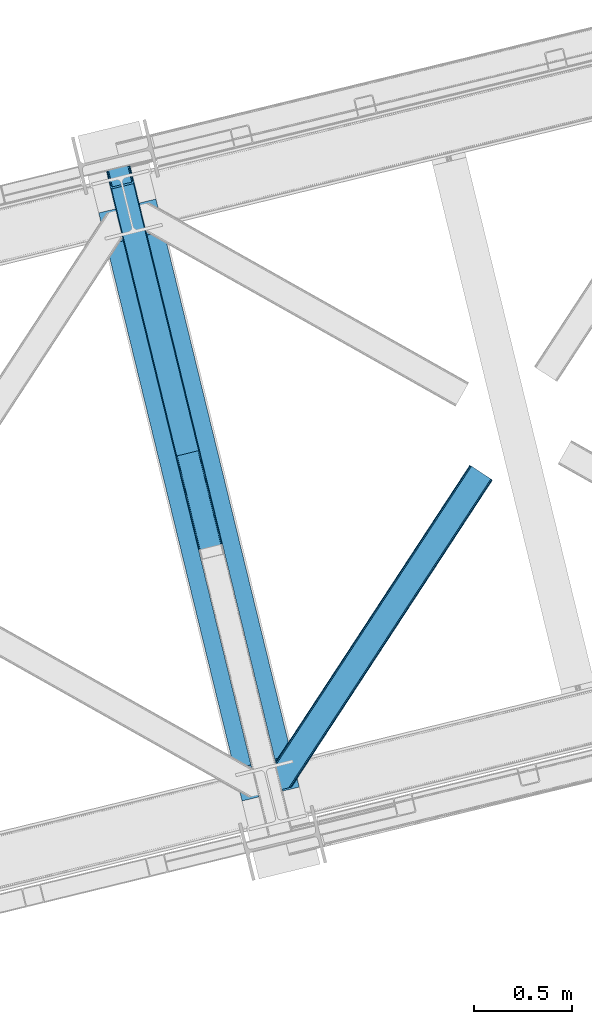
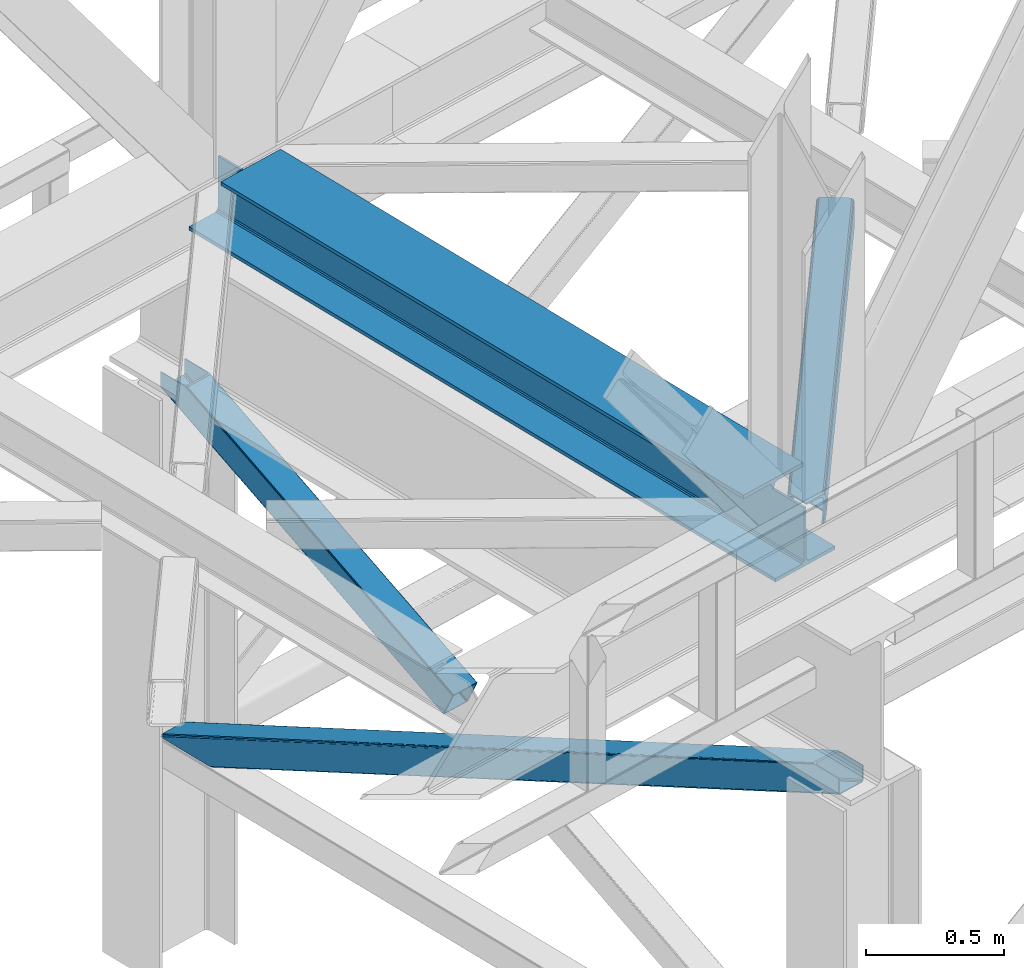
# One storey, part 44 of 93: 3 members, 1 beam.
"""IFC4 building model written with IfcOpenShell, lengths in millimetres."""

from ifc_helpers import new_model, entity, si_unit, converted_unit, derived_unit, direction, frame, origin, place, context, subcontext, project, spatial, triangles, polygons, material, type_object, element, save


model = new_model("IFC4")

# Units and contexts
model_context = context("Model", 3, precision=0.01, world=origin(), true_north=direction((6.12303176911189e-17, 1.0)))
plan_context = context("Plan", 3, precision=0.01, world=origin(), true_north=direction((6.12303176911189e-17, 1.0)))
body_context = subcontext(model_context, "Body", "Model", "MODEL_VIEW")
ifc_project = project(units=[si_unit("LENGTHUNIT", "METRE", prefix="MILLI"), si_unit("AREAUNIT", "SQUARE_METRE"), si_unit("VOLUMEUNIT", "CUBIC_METRE"), converted_unit("PLANEANGLEUNIT", "DEGREE", entity("IfcRatioMeasure", 0.0174532925199433), si_unit("PLANEANGLEUNIT", "RADIAN"), dimensions=[0, 0, 0, 0, 0, 0, 0]), si_unit("MASSUNIT", "GRAM", prefix="KILO"), derived_unit("MASSDENSITYUNIT", [(si_unit("MASSUNIT", "GRAM", prefix="KILO"), 1), (si_unit("LENGTHUNIT", "METRE"), -3)]), derived_unit("MOMENTOFINERTIAUNIT", [(si_unit("LENGTHUNIT", "METRE"), 4)]), si_unit("TIMEUNIT", "SECOND"), si_unit("FREQUENCYUNIT", "HERTZ"), si_unit("THERMODYNAMICTEMPERATUREUNIT", "DEGREE_CELSIUS"), derived_unit("THERMALTRANSMITTANCEUNIT", [(si_unit("MASSUNIT", "GRAM", prefix="KILO"), 1), (si_unit("THERMODYNAMICTEMPERATUREUNIT", "KELVIN"), -1), (si_unit("TIMEUNIT", "SECOND"), -3)]), derived_unit("VOLUMETRICFLOWRATEUNIT", [(si_unit("LENGTHUNIT", "METRE"), 3), (si_unit("TIMEUNIT", "SECOND"), -1)]), derived_unit("MASSFLOWRATEUNIT", [(si_unit("MASSUNIT", "GRAM", prefix="KILO"), 1), (si_unit("TIMEUNIT", "SECOND"), -1)]), derived_unit("ROTATIONALFREQUENCYUNIT", [(si_unit("TIMEUNIT", "SECOND"), -1)]), si_unit("ELECTRICCURRENTUNIT", "AMPERE"), si_unit("ELECTRICVOLTAGEUNIT", "VOLT"), si_unit("POWERUNIT", "WATT"), si_unit("FORCEUNIT", "NEWTON", prefix="KILO"), si_unit("ILLUMINANCEUNIT", "LUX"), si_unit("LUMINOUSFLUXUNIT", "LUMEN"), si_unit("LUMINOUSINTENSITYUNIT", "CANDELA"), derived_unit("USERDEFINED", [(si_unit("MASSUNIT", "GRAM", prefix="KILO"), -1), (si_unit("LENGTHUNIT", "METRE"), -2), (si_unit("TIMEUNIT", "SECOND"), 3), (si_unit("LUMINOUSFLUXUNIT", "LUMEN"), 1)]), derived_unit("LINEARVELOCITYUNIT", [(si_unit("LENGTHUNIT", "METRE"), 1), (si_unit("TIMEUNIT", "SECOND"), -1)]), si_unit("PRESSUREUNIT", "PASCAL"), derived_unit("USERDEFINED", [(si_unit("LENGTHUNIT", "METRE"), -2), (si_unit("MASSUNIT", "GRAM", prefix="KILO"), 1), (si_unit("TIMEUNIT", "SECOND"), -2)]), derived_unit("LINEARFORCEUNIT", [(si_unit("MASSUNIT", "GRAM", prefix="KILO"), 1), (si_unit("LENGTHUNIT", "METRE"), 1), (si_unit("TIMEUNIT", "SECOND"), -2), (si_unit("LENGTHUNIT", "METRE"), -1)]), derived_unit("PLANARFORCEUNIT", [(si_unit("MASSUNIT", "GRAM", prefix="KILO"), 1), (si_unit("LENGTHUNIT", "METRE"), 1), (si_unit("TIMEUNIT", "SECOND"), -2), (si_unit("LENGTHUNIT", "METRE"), -2)])], contexts=[model_context, plan_context])

# Site, building, storey
site_placement = place(None, origin())
site = spatial("IfcSite", under=ifc_project, at=site_placement, CompositionType="ELEMENT")
building_placement = place(site_placement, origin())
building = spatial("IfcBuilding", under=site, at=building_placement, CompositionType="ELEMENT")
storey_placement = place(building_placement, frame((0.0, 0.0, 15900.0)))
storey = spatial("IfcBuildingStorey", under=building, at=storey_placement, CompositionType="ELEMENT", Elevation=15900.0)

# Beam
ifc_material = material(Name="Metal painted (White)")
beam_type = type_object("IfcBeamType", PredefinedType="BEAM")
beam_placement = place(storey_placement, frame((-43083.0706492103, 7284.75052326422, 3385.0)))
element("IfcBeam", 1, at=beam_placement, inside=storey, type_object=beam_type, material=ifc_material, ObjectType="Steel Beam", PredefinedType="BEAM", context=body_context, shape_type="Tessellation", body=[
    polygons([(1022.42935345712, 71.047827897101, 15.4999999999986), (1022.42935345712, 71.047827897101, 0.0), (291.465617442438, 3069.74325535076, 0.0), (291.465617442438, 3069.74325535076, 15.4999999999986), (899.042242073144, 40.970914087328, 15.4999999999986), (168.078506058474, 3039.66634154099, 15.4999999999986), (892.34989829919, 39.3395844888232, 16.8701684147963), (161.386162284511, 3038.03501194248, 16.8701684147963), (886.676403198575, 37.9566100336508, 20.7720779386413), (155.712667183895, 3036.65203748731, 20.7720779386413), (882.88549497, 37.0325360459173, 26.6116982174294), (151.92175895532, 3035.72796349958, 26.6116982174294), (881.554305026594, 36.7080444135029, 33.500000000001), (150.590569011924, 3035.40347186716, 33.500000000001), (140.875048430514, 3033.03521093726, 33.500000000001), (140.875048430505, 3033.03521093726, 259.000000000002), (150.590569011924, 3035.40347186716, 259.000000000002), (0.0, 2998.69542745366, 0.0), (0.0, 2998.69542745366, 15.4999999999986), (123.387111383964, 3028.77234126343, 15.4999999999986), (130.079455157918, 3030.40367086194, 16.8701684147963), (135.752950258533, 3031.78664531711, 20.7720779386413), (139.543858487117, 3032.71071930484, 26.6116982174294), (881.554305026594, 36.7080444135029, 259.000000000002), (871.838784445184, 34.3397834835992, 259.000000000002), (871.838784445184, 34.3397834835992, 33.500000000001), (870.507594501788, 34.0152918511848, 26.6116982174294), (866.716686273213, 33.0912178634502, 20.7720779386413), (861.043191172597, 31.7082434082767, 16.8701684147963), (854.350847398634, 30.0769138097741, 15.4999999999986), (730.963736014671, -1.08286712929839e-12, 15.4999999999986), (730.963736014671, -1.08286712929839e-12, 0.0), (841.854534586231, 199.571930111232, 259.069791776412), (190.199733064555, 2872.911390143, 259.000000000002), (190.423126166404, 2871.99494573803, 259.61730333112), (190.43551501003, 2871.94412150426, 266.500003008253), (841.709355772731, 200.167408132524, 266.500002998871), (841.709705893484, 200.16597182779, 260.000004007589), (832.229597305427, 196.831858094285, 259.006343172366), (832.006227290695, 197.748309612731, 259.61730333112), (831.99383844707, 197.799133846503, 266.500003008253), (180.719997684377, 2869.57584721824, 266.500002998871), (180.719647563625, 2869.57728352297, 260.000004007589), (180.57484190528, 2870.17133233676, 259.07612046749), (180.484212483136, 2870.5431292131, 259.000000000002), (843.040843642659, 200.490677577209, 273.388305639783), (846.831120231355, 201.417342749122, 279.227924098781), (852.504191178885, 202.8020572128, 283.129832400619), (859.196382860018, 204.434010743611, 284.500000377228), (982.583411547862, 234.511263798724, 284.500000138971), (982.58174174121, 234.518113867456, 299.999995328161), (691.116319643931, 163.469484603412, 299.999995890962), (691.117989450592, 163.462634534681, 284.500000701776), (814.505018138436, 193.539887589793, 284.500000463519), (821.197505034574, 195.170630056371, 283.129832461069), (826.871416683343, 196.551895700895, 279.227924137322), (830.662951470326, 197.473399350192, 273.388305663684), (179.388509814458, 2869.25257777355, 273.388305639783), (175.598233225762, 2868.32591260164, 279.227924098781), (169.925162278224, 2866.94119813796, 283.129832400619), (163.23297059709, 2865.30924460715, 284.500000377228), (39.8459419092461, 2835.23199155204, 284.500000138971), (39.8476117159065, 2835.2251414833, 299.999995328161), (331.313033813168, 2906.27377074735, 299.999995890962), (331.311364006516, 2906.28062081608, 284.500000701776), (207.924335318672, 2876.20336776097, 284.500000463519), (201.231848422534, 2874.57262529439, 283.129832461069), (195.557936773773, 2873.19135964986, 279.227924137322), (191.766401986782, 2872.26985600057, 273.388305663684)], [[[1, 2, 3, 4]], [[5, 1, 4, 6]], [[7, 5, 6, 8]], [[9, 7, 8, 10]], [[11, 9, 10, 12]], [[13, 11, 12, 14]], [[15, 16, 17, 14, 12, 10, 8, 6, 4, 3, 18, 19, 20, 21, 22, 23]], [[13, 24, 25, 26, 27, 28, 29, 30, 31, 32, 2, 1, 5, 7, 9, 11]], [[2, 32, 18, 3]], [[32, 31, 19, 18]], [[31, 30, 20, 19]], [[27, 26, 15, 23]], [[28, 27, 23, 22]], [[29, 28, 22, 21]], [[30, 29, 21, 20]], [[33, 24, 13, 14, 17, 34, 35, 36, 37, 38]], [[25, 39, 40, 41, 42, 43, 44, 16, 15, 26]], [[39, 25, 24, 33]], [[45, 34, 17, 16]], [[41, 40, 38, 37, 46, 47, 48, 49, 50, 51, 52, 53, 54, 55, 56, 57]], [[42, 58, 59, 60, 61, 62, 63, 64, 65, 66, 67, 68, 69, 36, 35, 43]], [[46, 37, 36, 69]], [[47, 46, 69, 68]], [[48, 47, 68, 67]], [[49, 48, 67, 66]], [[50, 49, 66, 65]], [[51, 50, 65, 64]], [[52, 51, 64, 63]], [[53, 52, 63, 62]], [[54, 53, 62, 61]], [[55, 54, 61, 60]], [[56, 55, 60, 59]], [[57, 56, 59, 58]], [[41, 57, 58, 42]]], closed=False),
])

# Members
member_type_1 = type_object("IfcMemberType", PredefinedType="BRACE")
member_1_placement = place(storey_placement, frame((-43055.1349325336, 9044.27748104314, 1820.90870290301)))
element("IfcMember", 2, at=member_1_placement, inside=storey, type_object=member_type_1, ObjectType="Steel Vertical Brace", PredefinedType="BRACE", context=body_context, shape_type="Tessellation", body=[
    polygons([(29.8135191782804, 1388.61826467865, 771.091297096984), (32.1113287327941, 1381.7631169139, 771.091297096991), (368.111452939613, 3.36089743274961, 105.060837153753), (367.211709770158, 4.48063717441277, 102.289544138114), (35.2425975620211, 1376.24004026086, 771.091297096982), (370.05749831742, 2.70006492288988, 107.410225929579), (38.7306183717081, 1372.88987307313, 771.091297096984), (372.753578135707, 2.59874540397811, 108.980037321763), (42.0443716126081, 1372.2226479357, 771.091297096984), (375.789238682186, 3.07236385431782, 109.531281776207), (140.171129484899, 1396.14208332772, 771.091297096984), (473.915996554477, 26.9917992463432, 109.531281776209), (142.8061262653, 1398.25937921938, 771.091297096991), (476.829086029282, 27.9682515502273, 108.980037321769), (144.361212211704, 1402.83885703393, 771.091297096989), (479.176112967095, 29.2988816959539, 107.410225929583), (144.599639585679, 1409.18333278718, 771.091297096997), (480.599763792498, 30.7811133060287, 105.060837153757), (143.485109980834, 1416.32691755852, 771.091297096984), (480.883300572703, 32.1892900542821, 102.289544138114), (149.600536197998, 1408.12910918704, 771.09129709698), (121.444007267685, 1523.63806044727, 771.091297096982), (117.557799035119, 1522.69075607531, 771.09129709698), (3.88620823256572, 1494.98210319545, 771.091297096982), (0.0, 1494.03479882349, 771.091297096982), (28.1565289303128, 1378.52584756325, 771.09129709698), (30.4543384848352, 1371.6706997985, 771.091297096982), (33.5856073140622, 1366.14762314545, 771.091297096982), (37.0736281237578, 1362.79745595772, 771.091297096984), (40.3873813646492, 1362.1302308203, 771.09129709698), (146.286555702072, 1387.94427495624, 771.09129709698), (148.921552482473, 1390.06157084789, 771.091297096984), (150.476638428877, 1394.64104866244, 771.09129709698), (150.715065802835, 1400.9855244157, 771.09129709698), (359.725704690137, 52.0811507006387, 4.33146851719357e-12), (465.62487902756, 77.8951948365855, 2.16573425859679e-12), (468.660539574047, 78.3688132869252, 0.551244454446396), (471.356619392334, 78.2674937680167, 2.12105584662818), (473.302664770132, 77.6066612581483, 4.4704446224671), (474.202407939596, 76.4869215164884, 7.24173763810153), (485.172065028726, 31.4851533942341, 105.910412957166), (484.888528248495, 30.076976645984, 108.681705972796), (483.464877423117, 28.5947450359069, 111.031094748631), (481.117850485313, 27.2641148901782, 112.600906140819), (478.204761010508, 26.2876625862941, 113.152150595261), (372.305586673086, 0.473618450346206, 113.152150595257), (369.26992612659, 4.33146851719357e-12, 112.600906140819), (366.573846308302, 0.1013195189161, 111.031094748635), (364.627800930504, 0.762152028780159, 108.681705972796), (363.728057761041, 1.88189177044223, 105.910412957166), (352.758400671911, 46.8836598926955, 7.24173763810153), (353.041937452133, 48.2918366409467, 4.4704446224671), (354.465588277511, 49.7740682510248, 2.12105584662385), (356.812615215332, 51.1046983967513, 0.551244454448562), (470.718755930487, 73.8881761125179, 10.8626064571491), (469.819012761015, 75.0079158541778, 8.09131344151462), (467.872967383234, 75.6687483640494, 5.74192466567137), (465.17688756493, 75.7700678829514, 4.17211327349608), (462.141227018451, 75.296449432615, 3.62086881905185), (364.01446914616, 51.3770140405907, 3.62086881905185), (361.101379671346, 50.4005617367033, 4.17211327349392), (358.754352733533, 49.0699315909757, 5.74192466567787), (357.330701908147, 47.5876999809008, 8.09131344151462), (357.047165127933, 46.1795232326485, 10.8626064571491), (3.88620823255706, 1494.98210319545, 710.909831470177), (117.557799035128, 1522.69075607532, 710.909831470177), (11.6586246976972, 1496.87671193937, 702.072173549059), (8.91066050333388, 1496.20686659411, 703.366418586696), (6.16269630898794, 1495.53702124884, 704.660663624354), (5.02445227077683, 1495.25956222214, 707.785247547264), (116.419554996891, 1522.41329704861, 707.785247547264), (115.28131095868, 1522.13583802191, 704.660663624352), (112.533346764334, 1521.46599267665, 703.3664185867), (109.785382569988, 1520.79614733139, 702.072173549057), (120.305763229465, 1523.36060142058, 703.366418586704), (119.167519191254, 1523.08314239388, 700.241834663787), (116.4195549969, 1522.41329704862, 698.94758962614), (113.671590802554, 1521.74345170335, 697.653344588497), (7.77241646513144, 1495.92940756741, 697.653344588497), (5.02445227077683, 1495.25956222214, 698.947589626138), (2.27648807642222, 1494.58971687688, 700.241834663785), (1.13824403821977, 1494.31225785018, 703.366418586702), (0.0, 1494.03479882349, 706.491002509615), (121.444007267685, 1523.63806044727, 706.491002509615)], [[[1, 2, 3, 4]], [[2, 5, 6, 3]], [[5, 7, 8, 6]], [[7, 9, 10, 8]], [[9, 11, 12, 10]], [[11, 13, 14, 12]], [[13, 15, 16, 14]], [[15, 17, 18, 16]], [[17, 19, 20, 18]], [[21, 22, 23, 19, 17, 15, 13, 11, 9, 7, 5, 2, 1, 24, 25, 26, 27, 28, 29, 30, 31, 32, 33, 34]], [[35, 36, 37, 38, 39, 40, 41, 42, 43, 44, 45, 46, 47, 48, 49, 50, 51, 52, 53, 54], [55, 56, 57, 58, 59, 60, 61, 62, 63, 64, 4, 3, 6, 8, 10, 12, 14, 16, 18, 20]], [[24, 1, 4, 64, 65]], [[19, 23, 66, 55, 20]], [[61, 67, 68]], [[62, 68, 69]], [[63, 69, 70]], [[64, 70, 65]], [[70, 64, 63]], [[69, 63, 62]], [[68, 62, 61]], [[67, 61, 60]], [[55, 71, 56]], [[56, 72, 57]], [[57, 73, 58]], [[58, 74, 59]], [[74, 58, 73]], [[73, 57, 72]], [[72, 56, 71]], [[71, 55, 66]], [[74, 67, 60, 59]], [[75, 76, 77, 78, 79, 80, 81, 82, 83, 25, 24, 65, 70, 69, 68, 67, 74, 73, 72, 71, 66, 23, 22, 84]], [[30, 29, 47, 46]], [[29, 28, 48, 47]], [[28, 27, 49, 48]], [[27, 26, 50, 49]], [[45, 31, 30, 46]], [[21, 34, 42, 41]], [[34, 33, 43, 42]], [[33, 32, 44, 43]], [[32, 31, 45, 44]], [[50, 26, 25, 83, 51]], [[84, 22, 21, 41, 40]], [[51, 82, 52]], [[52, 81, 53]], [[53, 80, 54]], [[54, 79, 35]], [[79, 54, 80]], [[80, 53, 81]], [[81, 52, 82]], [[82, 51, 83]], [[37, 78, 77]], [[38, 77, 76]], [[39, 76, 75]], [[40, 75, 84]], [[75, 40, 39]], [[76, 39, 38]], [[77, 38, 37]], [[78, 37, 36]], [[35, 79, 78, 36]]], closed=True),
])
member_type_2 = type_object("IfcMemberType", PredefinedType="BRACE")
member_2_placement = place(storey_placement, frame((-43055.134753418, 7071.32883911133, 970.500476074218)))
element("IfcMember", 3, at=member_2_placement, inside=storey, type_object=member_type_2, ObjectType="Steel Vertical Brace", PredefinedType="BRACE", context=body_context, shape_type="Tessellation", body=[
    triangles([(177.817053222658, 3231.5446105957, 0.0), (958.783337402347, 27.7087738037108, 1548.06132202148), (852.887475585943, 1.89465179443323, 1548.06132202148), (71.9165405273452, 3205.72990722656, 0.0), (961.532006835943, 28.3785003662106, 1549.35542907715), (964.280676269533, 29.0482269287113, 1550.65069885254), (180.449450683598, 3233.66192321777, 0.0), (965.420141601564, 29.3255355834963, 1553.77492675781), (182.007495117192, 3238.24071350098, 0.0), (966.559606933595, 29.6034255981449, 1556.89915466309), (182.244689941406, 3244.58567504883, 0.0), (181.128479003906, 3251.72942504883, 0.0), (845.115856933597, 0.0, 1556.89915466309), (59.6847290039077, 3222.12541809082, 0.0), (61.9822631835996, 3215.27118530273, 0.0), (846.250671386719, 0.277308654784974, 1553.77492675781), (65.1169555664092, 3209.74710388184, 0.0), (847.39013671875, 0.554617309569949, 1550.65069885254), (68.6051147460967, 3206.39730834961, 0.0), (850.138806152347, 1.22492523193341, 1549.35542907715), (121.443750000006, 3496.58657226562, 2.0998718261726), (938.403186035161, 145.112072753906, 1621.4998626709), (121.443750000006, 3496.58657226562, 0.0), (966.559606933595, 29.6034255981449, 1621.4998626709), (0.0, 3466.98372802734, 2.0998718261726), (816.954785156253, 115.508647155762, 1621.4998626709), (0.0, 3466.98372802734, 0.0), (845.115856933597, 0.0, 1621.4998626709), (116.420800781256, 3495.36222839356, 9.64359741210865), (113.672131347659, 3494.69250183105, 10.9377044677749), (926.171374511723, 161.507583618164, 1621.4998626709), (119.164819335943, 3496.03195495605, 8.34949035644604), (929.482800292972, 160.840763854981, 1621.4998626709), (120.304284667975, 3496.30868225098, 5.22409973144386), (932.970959472659, 157.490386962891, 1621.4998626709), (936.105651855469, 151.967468261719, 1621.4998626709), (7.77161865234666, 3468.87779846191, 10.9377044677749), (820.270861816411, 135.69404296875, 1621.4998626709), (815.843225097662, 122.652397155762, 1621.4998626709), (1.13946533203125, 3467.26045532227, 5.22409973144386), (816.080419921876, 128.99677734375, 1621.4998626709), (2.27427978516062, 3467.53834533692, 8.34949035644604), (817.633813476568, 133.576148986816, 1621.4998626709), (5.02294921875, 3468.20807189941, 9.64359741210865), (4.15788574219187, 3467.99645690918, 0.0), (4.76250000000437, 3468.14528503418, 0.782510375975107), (6.7437744140625, 3468.6278137207, 3.34281921386719), (117.285864257814, 3495.57268066406, 0.0), (116.797521972658, 3495.45408325195, 0.95459289550854), (115.281335449225, 3495.08433837891, 3.92999267578125), (8.68319091797457, 3469.09987792969, 5.84615478515479), (109.783996582031, 3493.74488525391, 6.51936950683739), (11.6597534179746, 3469.82541503906, 6.51936950683739), (112.532666015628, 3494.41461181641, 5.22409973144386), (924.511010742193, 151.415176391602, 1621.4998626709), (826.386767578129, 127.496287536621, 1621.4998626709), (118.727636718751, 3490.84157409668, 0.0), (936.742822265631, 135.019665527344, 1621.4998626709), (934.445288085939, 141.875061035156, 1621.4998626709), (931.315246582031, 147.397979736328, 1621.4998626709), (927.827087402344, 150.748356628418, 1621.4998626709), (962.671472167975, 28.6558090209965, 1621.4998626709), (822.196325683595, 120.799603271485, 1621.4998626709), (823.749719238287, 125.378974914551, 1621.4998626709), (823.070690917972, 107.310891723633, 1621.4998626709), (821.959130859381, 114.454641723632, 1621.4998626709), (848.999340820315, 0.947035217284792, 1621.4998626709), (5.05550537109957, 3463.13280029297, 0.0), (175.012573242188, 3259.92659912109, 0.0), (962.671472167975, 28.6558090209965, 1561.31865234375), (61.3450927734375, 3232.21782531738, 0.0), (848.999340820315, 0.947035217284792, 1561.31865234375), (66.7726684570371, 3219.84067382813, 0.0), (63.6426269531294, 3225.3635925293, 0.0), (70.2608276367246, 3216.48971557617, 0.0), (73.576904296875, 3215.82231445312, 0.0), (175.891589355473, 3246.43905029297, 0.0), (176.128784179688, 3252.78401184082, 0.0), (174.338195800781, 3241.85909729004, 0.0), (171.701147460939, 3239.74178466797, 0.0), (954.899853515628, 26.7611572265623, 1552.48081970215), (957.648522949225, 27.4314651489258, 1553.77492675781), (960.392541503912, 28.1011917114256, 1555.06903381348), (856.770959472662, 2.84226837158167, 1552.48081970215), (854.022290039065, 2.17196044921911, 1553.77492675781), (851.278271484378, 1.50223388671839, 1555.06903381348), (961.532006835943, 28.3785003662106, 1558.19326171875), (850.138806152347, 1.22492523193341, 1558.19326171875)], [[1, 2, 3], [3, 4, 1], [5, 2, 1], [6, 5, 7], [8, 6, 9], [10, 8, 11], [11, 12, 10], [9, 11, 8], [7, 9, 6], [1, 7, 5], [13, 14, 15], [16, 15, 17], [18, 17, 19], [20, 19, 4], [4, 3, 20], [19, 20, 18], [17, 18, 16], [15, 16, 13], [12, 21, 22], [12, 23, 21], [22, 10, 12], [24, 10, 22], [25, 14, 26], [14, 25, 27], [13, 26, 14], [28, 26, 13], [29, 30, 31], [32, 29, 33], [34, 32, 35], [21, 34, 36], [36, 22, 21], [35, 36, 34], [33, 35, 32], [31, 33, 29], [31, 30, 37], [37, 38, 31], [25, 26, 39], [40, 39, 41], [42, 41, 43], [44, 43, 38], [38, 37, 44], [43, 44, 42], [41, 42, 40], [39, 40, 25], [45, 25, 46], [45, 27, 25], [46, 40, 47], [40, 42, 47], [25, 40, 46], [48, 21, 23], [21, 48, 49], [49, 34, 21], [34, 49, 50], [47, 44, 51], [37, 30, 52], [53, 51, 37], [52, 53, 37], [51, 44, 37], [42, 44, 47], [30, 54, 52], [29, 50, 54], [50, 32, 34], [50, 29, 32], [30, 29, 54], [52, 55, 56], [56, 53, 52], [57, 58, 59], [49, 48, 57], [49, 59, 60], [50, 60, 61], [54, 61, 55], [55, 52, 54], [61, 54, 50], [60, 50, 49], [59, 49, 57], [61, 60, 36], [35, 61, 36], [61, 35, 33], [55, 31, 38], [33, 55, 61], [31, 55, 33], [60, 22, 36], [24, 58, 62], [24, 22, 58], [60, 59, 22], [59, 58, 22], [39, 63, 64], [38, 56, 55], [56, 43, 64], [43, 56, 38], [64, 41, 39], [41, 64, 43], [26, 63, 39], [65, 66, 26], [66, 63, 26], [65, 28, 67], [26, 28, 65], [47, 51, 64], [46, 47, 63], [68, 46, 66], [66, 65, 68], [68, 45, 46], [63, 66, 46], [64, 63, 47], [53, 56, 51], [64, 51, 56], [58, 69, 70], [58, 57, 69], [70, 62, 58], [71, 65, 72], [65, 71, 68], [67, 72, 65], [73, 15, 14], [27, 68, 71], [68, 27, 45], [14, 71, 74], [71, 14, 27], [74, 73, 14], [75, 15, 73], [17, 75, 19], [17, 15, 75], [19, 76, 4], [4, 76, 1], [75, 76, 19], [12, 11, 77], [78, 69, 12], [77, 78, 12], [23, 57, 48], [69, 23, 12], [57, 23, 69], [11, 79, 77], [80, 7, 1], [80, 1, 76], [80, 79, 7], [79, 9, 7], [79, 11, 9], [81, 3, 2], [2, 5, 82], [6, 83, 5], [83, 82, 5], [2, 82, 81], [83, 6, 8], [84, 3, 81], [20, 85, 86], [20, 3, 85], [86, 18, 20], [18, 86, 16], [84, 85, 3], [87, 10, 70], [8, 87, 83], [10, 87, 8], [24, 70, 10], [24, 62, 70], [16, 88, 13], [13, 88, 72], [86, 88, 16], [72, 28, 13], [28, 72, 67], [81, 80, 84], [76, 84, 80], [70, 69, 78], [87, 78, 77], [83, 77, 79], [82, 79, 80], [80, 81, 82], [79, 82, 83], [77, 83, 87], [78, 87, 70], [85, 84, 76], [86, 85, 75], [88, 86, 73], [72, 88, 74], [74, 71, 72], [73, 74, 88], [75, 73, 86], [76, 75, 85]]),
])
member_type_3 = type_object("IfcMemberType", PredefinedType="BRACE")
member_3_placement = place(storey_placement, frame((-42217.8230712891, 7332.57045135498, 3511.0000579834)))
element("IfcMember", 4, at=member_3_placement, inside=storey, type_object=member_type_3, ObjectType="Steel Horizontal Brace", PredefinedType="BRACE", context=body_context, shape_type="Tessellation", body=[
    triangles([(109.770043945311, 259.950411987305, 7.52047119140843), (115.034838867192, 238.366264343262, 7.77510681152489), (114.220935058598, 239.947563171387, 8.3320495605476), (108.811962890628, 259.663220214844, 8.52041015625218), (113.639575195317, 239.860359191895, 8.52041015625218), (112.211755371092, 237.678515625, 8.52041015625218), (91.0363037109419, 232.517202758789, 8.52041015625218), (109.537499999999, 237.026229858398, 9.50058288574292), (90.2642578125015, 232.328842163086, 9.50058288574292), (5.02294921875, 77.405158996582, 9.50058288574292), (0.62786865234375, 95.4313842773436, 9.50058288574292), (1046.62448730469, 1651.75382995605, 6.99957275390625), (1041.02482910157, 1655.42279205322, 8.3320495605476), (116.704504394533, 231.514938354492, 6.99957275390625), (1036.27163085937, 1658.53248596191, 12.1260040283232), (3.93464355469041, 81.8758163452148, 12.1260040283232), (1033.09973144531, 1660.61084747314, 17.8035644531265), (2.70216064453416, 86.9220199584961, 17.8035644531265), (1031.98352050781, 1661.3398727417, 24.4996673583992), (2.26962890625146, 88.6945861816403, 24.4996673583992), (1122.759375, 1601.905128479, 6.99957275390625), (146.20968017578, 110.459536743164, 6.99957275390625), (1031.98352050781, 1661.3398727417, 115.501089477541), (2.26962890625146, 88.6945861816403, 115.501089477541), (1033.09973144531, 1660.61084747314, 122.196029663086), (2.70216064453416, 86.9220199584961, 122.196029663086), (1036.27163085937, 1658.53248596191, 127.87475280762), (3.93464355469041, 81.8758163452148, 127.87475280762), (1041.02482910157, 1655.42279205322, 131.667544555665), (5.77174072265916, 74.3233703613278, 131.667544555665), (1046.62448730469, 1651.75382995605, 133.000021362306), (7.94370117187646, 65.4146118164063, 133.000021362306), (1027.24427490235, 1664.44491577148, 10.8028289794929), (0.520898437498545, 95.8720550537109, 10.8691040039084), (0.0, 98.0062271118168, 17.5000946044929), (1035.16472167969, 1659.25686035156, 1.33247680664135), (112.262915039064, 249.735919189453, 1.33247680664135), (110.546740722661, 256.77269897461, 5.59500732422021), (109.077062988283, 259.839953613281, 8.31925964355469), (1030.41617431641, 1662.36713562012, 5.12526855468968), (1040.76903076172, 1655.58847961426, 0.0), (114.434875488281, 240.827160644531, 0.0), (1026.12806396485, 1665.1745223999, 17.5000946044929), (1128.61483154297, 1598.07106018066, 0.0), (148.479309082031, 101.147895812988, 0.0), (150.651269531249, 92.2391372680668, 1.33247680664135), (148.511865234374, 101.029879760742, 8.50064392089917), (152.493017578126, 84.6866912841797, 5.12526855468968), (153.348779296874, 81.1828353881838, 8.50064392089917), (1026.12806396485, 1665.1745223999, 122.500662231447), (0.0, 98.0062271118168, 122.500662231447), (1040.76903076172, 1655.58847961426, 139.999594116212), (1035.16472167969, 1659.25686035156, 138.667117309571), (3.50211181640771, 83.6350112915043, 138.667117309571), (5.674072265625, 74.7262527465818, 139.999594116212), (1030.41617431641, 1662.36713562012, 134.874325561526), (1.66501464843896, 91.1874572753904, 134.874325561526), (1027.24427490235, 1664.44491577148, 129.197927856447), (0.432531738282705, 96.2342422485353, 129.197927856447), (23.8915649414048, 0.0, 139.999594116212), (23.8915649414048, 0.0, 133.000021362306), (1128.61483154297, 1598.07106018066, 139.999594116212), (93.3384887695356, 16.9286178588864, 139.999594116212), (1122.759375, 1601.905128479, 133.000021362306), (83.3809570312515, 14.5014404296871, 133.000021362306), (1143.25579833984, 1588.48443603516, 122.500662231447), (1142.13958740234, 1589.21404266357, 129.197927856447), (118.225341796875, 22.9956893920898, 122.500662231447), (116.332434082033, 22.5340896606449, 129.197927856447), (1138.96768798828, 1591.2924041748, 134.874325561526), (110.937414550783, 21.219053649902, 134.874325561526), (1134.2144897461, 1594.4020980835, 138.667117309571), (102.86348876953, 19.2505691528322, 138.667117309571), (1143.25579833984, 1588.48443603516, 17.5000946044929), (118.225341796875, 22.9956893920898, 17.5000946044929), (1142.13958740234, 1589.21404266357, 10.8028289794929), (1133.11223144532, 1595.12705383301, 12.1260040283232), (1136.28413085938, 1593.04869232178, 17.8035644531265), (1137.40034179688, 1592.31908569336, 24.4996673583992), (1138.96768798828, 1591.2924041748, 5.12526855468968), (1134.2144897461, 1594.4020980835, 1.33247680664135), (1128.35903320312, 1598.2367477417, 8.3320495605476), (1133.11223144532, 1595.12705383301, 127.87475280762), (1137.40034179688, 1592.31908569336, 115.501089477541), (1136.28413085938, 1593.04869232178, 122.196029663086), (1128.35903320312, 1598.2367477417, 131.667544555665), (92.9059570312529, 16.823391723633, 131.667544555665), (100.979882812499, 18.7918762207028, 127.87475280762), (106.374902343749, 20.1069122314457, 122.196029663086), (108.2724609375, 20.5690933227543, 115.501089477541), (108.2724609375, 20.5690933227543, 24.4996673583992), (100.979882812499, 18.7918762207028, 12.1260040283232), (115.472021484376, 22.3248001098636, 9.50058288574292), (106.374902343749, 20.1069122314457, 17.8035644531265), (96.2034301757813, 17.6268310546875, 9.50058288574292), (115.946411132813, 22.4393280029299, 10.8702667236357), (153.065075683597, 80.2398696899418, 9.00061340332104), (152.776721191411, 79.2974853515625, 9.50058288574292), (148.711853027344, 99.8683227539059, 8.8831787109375), (148.604882812499, 99.0241882324217, 9.08781738281323), (148.493261718751, 98.1678451538082, 9.29478149414354), (148.386291503906, 97.3231292724613, 9.50058288574292)], [[1, 2, 3], [4, 5, 6], [6, 7, 4], [7, 6, 8], [8, 9, 7], [9, 8, 10], [10, 11, 9], [12, 13, 3], [3, 2, 12], [2, 14, 12], [15, 16, 8], [8, 13, 15], [8, 5, 13], [16, 10, 8], [8, 6, 5], [15, 17, 18], [18, 16, 15], [17, 19, 20], [20, 18, 17], [21, 12, 14], [14, 22, 21], [19, 23, 20], [24, 20, 23], [23, 25, 24], [26, 24, 25], [25, 27, 26], [28, 26, 27], [27, 29, 28], [30, 28, 29], [29, 31, 30], [32, 30, 31], [33, 34, 35], [36, 37, 38], [33, 4, 9], [33, 1, 39], [9, 34, 33], [9, 11, 34], [4, 7, 9], [40, 38, 1], [1, 33, 40], [38, 40, 36], [36, 41, 37], [42, 37, 41], [35, 43, 33], [41, 44, 42], [45, 42, 44], [14, 42, 22], [37, 2, 38], [2, 37, 42], [38, 2, 1], [42, 14, 2], [22, 42, 45], [46, 47, 45], [47, 46, 48], [45, 47, 22], [48, 49, 47], [50, 43, 35], [35, 51, 50], [52, 53, 54], [54, 55, 52], [53, 56, 57], [57, 54, 53], [56, 58, 59], [59, 57, 56], [58, 50, 51], [51, 59, 58], [28, 57, 26], [30, 32, 55], [32, 60, 55], [32, 61, 60], [54, 30, 55], [28, 54, 57], [16, 11, 10], [28, 30, 54], [51, 35, 20], [24, 26, 51], [24, 51, 20], [57, 59, 26], [26, 59, 51], [35, 18, 20], [18, 11, 16], [11, 18, 34], [35, 34, 18], [62, 55, 63], [62, 52, 55], [55, 60, 63], [64, 32, 31], [32, 64, 65], [61, 32, 65], [66, 67, 68], [69, 68, 67], [67, 70, 69], [71, 69, 70], [70, 72, 71], [73, 71, 72], [72, 62, 73], [63, 73, 62], [74, 66, 68], [68, 75, 74], [76, 77, 78], [79, 66, 74], [76, 78, 74], [76, 80, 77], [78, 79, 74], [77, 80, 81], [21, 44, 41], [44, 82, 81], [82, 44, 21], [82, 77, 81], [67, 83, 70], [84, 66, 79], [66, 85, 67], [85, 66, 84], [67, 85, 83], [62, 64, 52], [72, 70, 83], [83, 86, 72], [86, 64, 62], [62, 72, 86], [15, 36, 40], [41, 12, 21], [41, 13, 12], [13, 41, 36], [15, 13, 36], [19, 43, 50], [33, 17, 15], [40, 33, 15], [17, 33, 43], [19, 17, 43], [53, 27, 56], [52, 64, 31], [31, 29, 52], [29, 27, 53], [53, 52, 29], [58, 56, 27], [50, 23, 19], [25, 50, 58], [50, 25, 23], [25, 58, 27], [64, 86, 87], [87, 65, 64], [86, 83, 88], [88, 87, 86], [83, 85, 89], [89, 88, 83], [85, 84, 90], [90, 89, 85], [84, 79, 90], [91, 90, 79], [89, 68, 69], [87, 73, 63], [60, 65, 63], [65, 60, 61], [65, 87, 63], [88, 73, 87], [88, 89, 71], [71, 73, 88], [69, 71, 89], [91, 75, 68], [92, 93, 94], [89, 90, 68], [92, 95, 93], [91, 94, 75], [90, 91, 68], [96, 75, 94], [94, 93, 96], [76, 74, 75], [49, 80, 97], [98, 97, 80], [49, 48, 80], [76, 96, 98], [98, 80, 76], [96, 93, 98], [44, 81, 45], [46, 45, 81], [81, 80, 46], [48, 46, 80], [75, 96, 76], [82, 21, 22], [77, 82, 47], [47, 99, 77], [77, 100, 101], [100, 77, 99], [101, 102, 77], [77, 102, 92], [95, 92, 102], [22, 47, 82], [79, 78, 91], [94, 91, 78], [78, 77, 94], [92, 94, 77], [102, 101, 98], [101, 100, 97], [100, 99, 49], [99, 47, 49], [102, 98, 93], [93, 95, 102]]),
])

save(model, "model.ifc")
